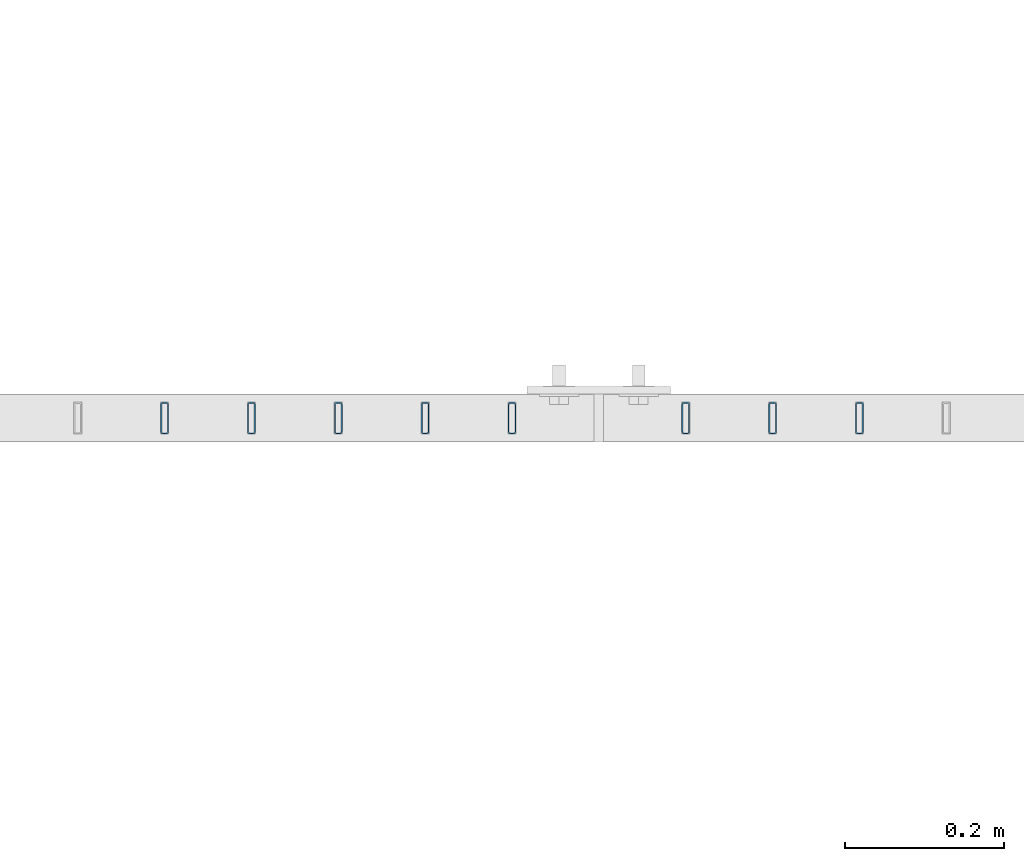
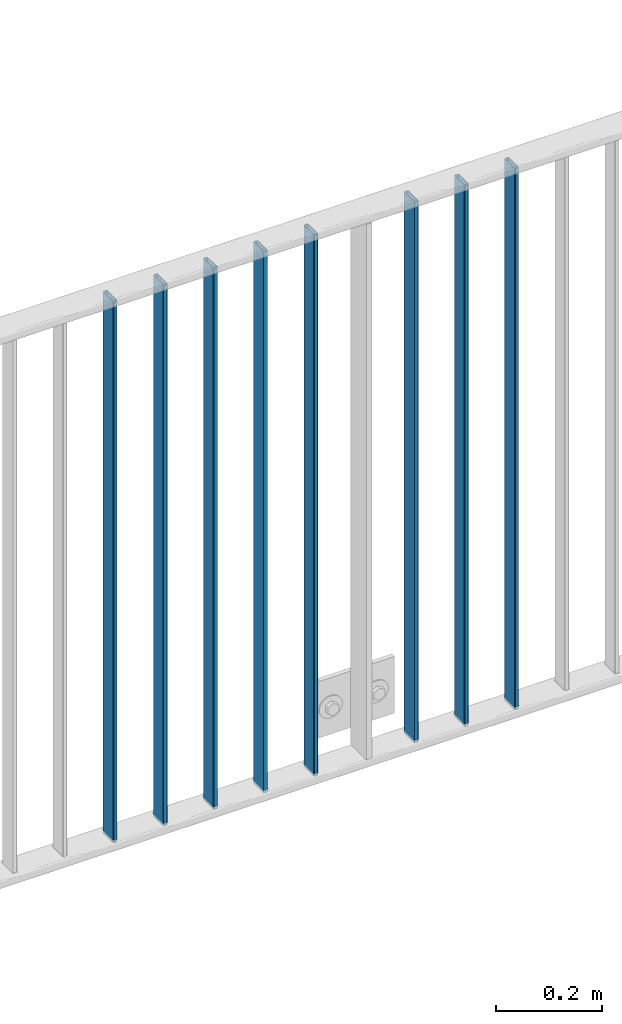
# One storey, part 10 of 156: 8 beams, 1 element without a shape of its own.
"""IFC2X3 building model written with IfcOpenShell, lengths in millimetres."""

from ifc_helpers import new_model, si_unit, frame, origin_with_axes, origin_2d_with_axis, place, context, subcontext, project, spatial, hollow_rectangle, extrude, clip, halfspace, material, type_object, element, aggregate, save


model = new_model("IFC2X3")

# Units and contexts
model_context = context("Model", 3, precision=1e-05, world=origin_with_axes())
body_context = subcontext(model_context, "Body", "Model", "MODEL_VIEW")
ifc_project = project(units=[si_unit("LENGTHUNIT", "METRE", prefix="MILLI"), si_unit("AREAUNIT", "SQUARE_METRE"), si_unit("VOLUMEUNIT", "CUBIC_METRE"), si_unit("MASSUNIT", "GRAM", prefix="KILO"), si_unit("TIMEUNIT", "SECOND"), si_unit("PLANEANGLEUNIT", "RADIAN"), si_unit("SOLIDANGLEUNIT", "STERADIAN"), si_unit("THERMODYNAMICTEMPERATUREUNIT", "DEGREE_CELSIUS"), si_unit("LUMINOUSINTENSITYUNIT", "LUMEN")], contexts=[model_context])

# Site, building, storey
site_placement = place(None, origin_with_axes())
site = spatial("IfcSite", under=ifc_project, at=site_placement, CompositionType="ELEMENT")
building_placement = place(site_placement, origin_with_axes())
building = spatial("IfcBuilding", under=site, at=building_placement, Name="Undefined", CompositionType="ELEMENT")
storey_placement = place(building_placement, origin_with_axes())
storey = spatial("IfcBuildingStorey", under=building, at=storey_placement, Name="Undefined", CompositionType="ELEMENT", Elevation=0.0)

# Assembly, beams
assembly_placement = place(storey_placement, origin_with_axes())
assembly = element("IfcElementAssembly", 1, at=assembly_placement, inside=storey, AssemblyPlace="NOTDEFINED", PredefinedType="RIGID_FRAME")
ifc_material = material(Name="STEEL/S235JR")
beam_type = type_object("IfcBeamType", Name="K40/10/1.5", PredefinedType="NOTDEFINED")
beam_1_placement = place(assembly_placement, frame((24127.269999999, 10879.9998088346, 3980.00000000003), z_axis=(0.0, 1.0, 0.0), x_axis=(0.0, 0.0, -1.0)))
beam_1 = element("IfcBeam", 2, at=beam_1_placement, type_object=beam_type, material=ifc_material, ObjectType="K40/10/1.5", context=body_context, shape_type="Clipping", body=[
    clip(clip(extrude(hollow_rectangle(XDim=10.0, YDim=40.0, WallThickness=1.5, InnerFilletRadius=1.5, OuterFilletRadius=3.0, at=origin_2d_with_axis()), frame((1237.00000000003, 0.0, 0.0), z_axis=(-1.0, 0.0, 0.0), x_axis=(0.0, -1.0, 0.0)), (0.0, 0.0, 1.0), 1244.0), halfspace(frame((1237.00000000003, 4.34248751949781, 47.3810900558092), z_axis=(1.0, 0.0, 0.0), x_axis=(0.0, -0.768354814194188, -0.640024124158313)), False)), halfspace(frame((-6.99999999997453, -4.34248751950508, 47.3810900558092), z_axis=(-1.0, 0.0, 0.0), x_axis=(0.0, 0.766598961668776, -0.642126180721792)), False)),
])
beam_2_placement = place(assembly_placement, frame((24018.179999999, 10879.9998088346, 3980.00000000003), z_axis=(0.0, 1.0, 0.0), x_axis=(0.0, 0.0, -1.0)))
beam_2 = element("IfcBeam", 3, at=beam_2_placement, type_object=beam_type, material=ifc_material, ObjectType="K40/10/1.5", context=body_context, shape_type="Clipping", body=[
    clip(clip(extrude(hollow_rectangle(XDim=10.0, YDim=40.0, WallThickness=1.5, InnerFilletRadius=1.5, OuterFilletRadius=3.0, at=origin_2d_with_axis()), frame((1237.00000000003, 0.0, 0.0), z_axis=(-1.0, 0.0, 0.0), x_axis=(0.0, -1.0, 0.0)), (0.0, 0.0, 1.0), 1244.0), halfspace(frame((1237.00000000003, 4.34248751949781, 47.3810900558092), z_axis=(1.0, 0.0, 0.0), x_axis=(0.0, -0.768354814194188, -0.640024124158313)), False)), halfspace(frame((-6.99999999997453, -4.34248751950508, 47.3810900558092), z_axis=(-1.0, 0.0, 0.0), x_axis=(0.0, 0.766598961668776, -0.642126180721792)), False)),
])
beam_3_placement = place(assembly_placement, frame((23909.089999999, 10879.9998088346, 3980.00000000003), z_axis=(0.0, 1.0, 0.0), x_axis=(0.0, 0.0, -1.0)))
beam_3 = element("IfcBeam", 4, at=beam_3_placement, type_object=beam_type, material=ifc_material, ObjectType="K40/10/1.5", context=body_context, shape_type="Clipping", body=[
    clip(clip(extrude(hollow_rectangle(XDim=10.0, YDim=40.0, WallThickness=1.5, InnerFilletRadius=1.5, OuterFilletRadius=3.0, at=origin_2d_with_axis()), frame((1237.00000000003, 0.0, 0.0), z_axis=(-1.0, 0.0, 0.0), x_axis=(0.0, -1.0, 0.0)), (0.0, 0.0, 1.0), 1244.0), halfspace(frame((1237.00000000003, 4.34248751949781, 47.3810900558092), z_axis=(1.0, 0.0, 0.0), x_axis=(0.0, -0.768354814194188, -0.640024124158313)), False)), halfspace(frame((-6.99999999997453, -4.34248751950508, 47.3810900558092), z_axis=(-1.0, 0.0, 0.0), x_axis=(0.0, 0.763991285051099, -0.645226562043109)), False)),
])
beam_4_placement = place(assembly_placement, frame((23690.899999999, 10879.9998088346, 3980.00000000003), z_axis=(0.0, 1.0, 0.0), x_axis=(0.0, 0.0, -1.0)))
beam_4 = element("IfcBeam", 5, at=beam_4_placement, type_object=beam_type, material=ifc_material, ObjectType="K40/10/1.5", context=body_context, shape_type="Clipping", body=[
    clip(clip(extrude(hollow_rectangle(XDim=10.0, YDim=40.0, WallThickness=1.5, InnerFilletRadius=1.5, OuterFilletRadius=3.0, at=origin_2d_with_axis()), frame((1237.00000000003, 0.0, 0.0), z_axis=(-1.0, 0.0, 0.0), x_axis=(0.0, -1.0, 0.0)), (0.0, 0.0, 1.0), 1244.0), halfspace(frame((1237.00000000003, 4.34248751949781, 47.3810900558092), z_axis=(1.0, 0.0, 0.0), x_axis=(0.0, -0.768354814194188, -0.640024124158313)), False)), halfspace(frame((-6.99999999997453, -4.34248751950508, 47.3810900558092), z_axis=(-1.0, 0.0, 0.0), x_axis=(0.0, 0.763991285051099, -0.645226562043109)), False)),
])
beam_5_placement = place(assembly_placement, frame((23581.809999999, 10879.9998088346, 3980.00000000003), z_axis=(0.0, 1.0, 0.0), x_axis=(0.0, 0.0, -1.0)))
beam_5 = element("IfcBeam", 6, at=beam_5_placement, type_object=beam_type, material=ifc_material, ObjectType="K40/10/1.5", context=body_context, shape_type="Clipping", body=[
    clip(clip(extrude(hollow_rectangle(XDim=10.0, YDim=40.0, WallThickness=1.5, InnerFilletRadius=1.5, OuterFilletRadius=3.0, at=origin_2d_with_axis()), frame((1237.00000000003, 0.0, 0.0), z_axis=(-1.0, 0.0, 0.0), x_axis=(0.0, -1.0, 0.0)), (0.0, 0.0, 1.0), 1244.0), halfspace(frame((1237.00000000003, 4.34248751949781, 47.3810900558092), z_axis=(1.0, 0.0, 0.0), x_axis=(0.0, -0.768354814194188, -0.640024124158313)), False)), halfspace(frame((-6.99999999997453, -4.34248751950508, 47.3810900558092), z_axis=(-1.0, 0.0, 0.0), x_axis=(0.0, 0.763991285051099, -0.645226562043109)), False)),
])
beam_6_placement = place(assembly_placement, frame((23472.719999999, 10879.9998088346, 3980.00000000003), z_axis=(0.0, 1.0, 0.0), x_axis=(0.0, 0.0, -1.0)))
beam_6 = element("IfcBeam", 7, at=beam_6_placement, type_object=beam_type, material=ifc_material, ObjectType="K40/10/1.5", context=body_context, shape_type="Clipping", body=[
    clip(clip(extrude(hollow_rectangle(XDim=10.0, YDim=40.0, WallThickness=1.5, InnerFilletRadius=1.5, OuterFilletRadius=3.0, at=origin_2d_with_axis()), frame((1237.00000000003, 0.0, 0.0), z_axis=(-1.0, 0.0, 0.0), x_axis=(0.0, -1.0, 0.0)), (0.0, 0.0, 1.0), 1244.0), halfspace(frame((1237.00000000003, 4.34248751949781, 47.3810900558092), z_axis=(1.0, 0.0, 0.0), x_axis=(0.0, -0.768354814194188, -0.640024124158313)), False)), halfspace(frame((-6.99999999997453, -4.34248751950508, 47.3810900558092), z_axis=(-1.0, 0.0, 0.0), x_axis=(0.0, 0.763991285051099, -0.645226562043109)), False)),
])
beam_7_placement = place(assembly_placement, frame((23363.629999999, 10879.9998088346, 3980.00000000003), z_axis=(0.0, 1.0, 0.0), x_axis=(0.0, 0.0, -1.0)))
beam_7 = element("IfcBeam", 8, at=beam_7_placement, type_object=beam_type, material=ifc_material, ObjectType="K40/10/1.5", context=body_context, shape_type="Clipping", body=[
    clip(clip(extrude(hollow_rectangle(XDim=10.0, YDim=40.0, WallThickness=1.5, InnerFilletRadius=1.5, OuterFilletRadius=3.0, at=origin_2d_with_axis()), frame((1237.00000000003, 0.0, 0.0), z_axis=(-1.0, 0.0, 0.0), x_axis=(0.0, -1.0, 0.0)), (0.0, 0.0, 1.0), 1244.0), halfspace(frame((1237.00000000003, 4.34248751949781, 47.3810900558092), z_axis=(1.0, 0.0, 0.0), x_axis=(0.0, -0.768354814194188, -0.640024124158313)), False)), halfspace(frame((-6.99999999997453, -4.34248751950508, 47.3810900558092), z_axis=(-1.0, 0.0, 0.0), x_axis=(0.0, 0.763991285051099, -0.645226562043109)), False)),
])
beam_8_placement = place(assembly_placement, frame((23254.539999999, 10879.9998088346, 3980.00000000003), z_axis=(0.0, 1.0, 0.0), x_axis=(0.0, 0.0, -1.0)))
beam_8 = element("IfcBeam", 9, at=beam_8_placement, type_object=beam_type, material=ifc_material, ObjectType="K40/10/1.5", context=body_context, shape_type="Clipping", body=[
    clip(clip(extrude(hollow_rectangle(XDim=10.0, YDim=40.0, WallThickness=1.5, InnerFilletRadius=1.5, OuterFilletRadius=3.0, at=origin_2d_with_axis()), frame((1237.00000000003, 0.0, 0.0), z_axis=(-1.0, 0.0, 0.0), x_axis=(0.0, -1.0, 0.0)), (0.0, 0.0, 1.0), 1244.0), halfspace(frame((1237.00000000003, 4.34248751949781, 47.3810900558092), z_axis=(1.0, 0.0, 0.0), x_axis=(0.0, -0.768354814194188, -0.640024124158313)), False)), halfspace(frame((-6.99999999997453, -4.34248751950508, 47.3810900558092), z_axis=(-1.0, 0.0, 0.0), x_axis=(0.0, 0.763991285051099, -0.645226562043109)), False)),
])
aggregate(assembly, [beam_1, beam_2, beam_3, beam_4, beam_5, beam_6, beam_7, beam_8])

save(model, "model.ifc")
